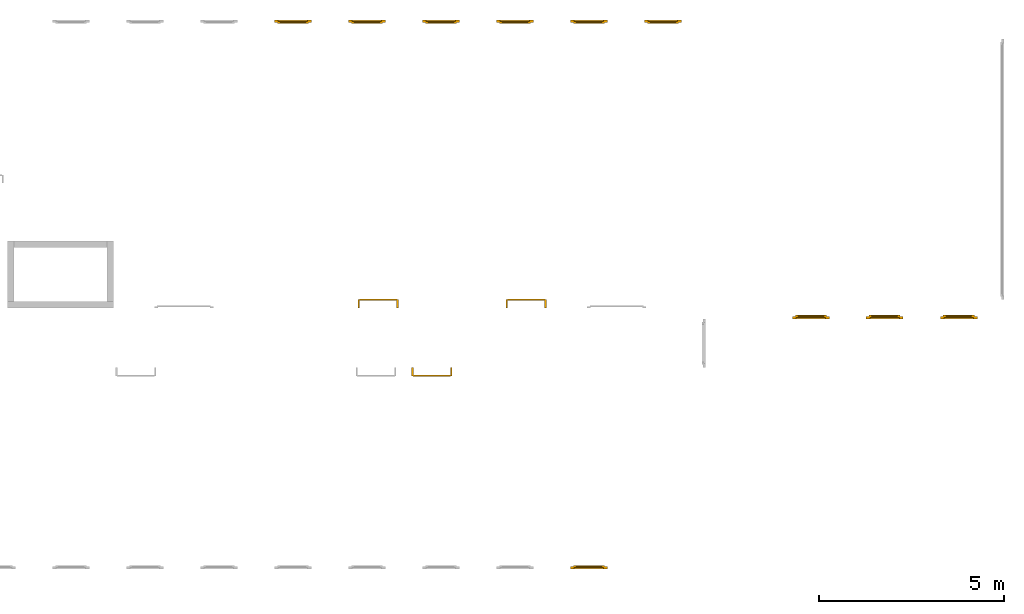
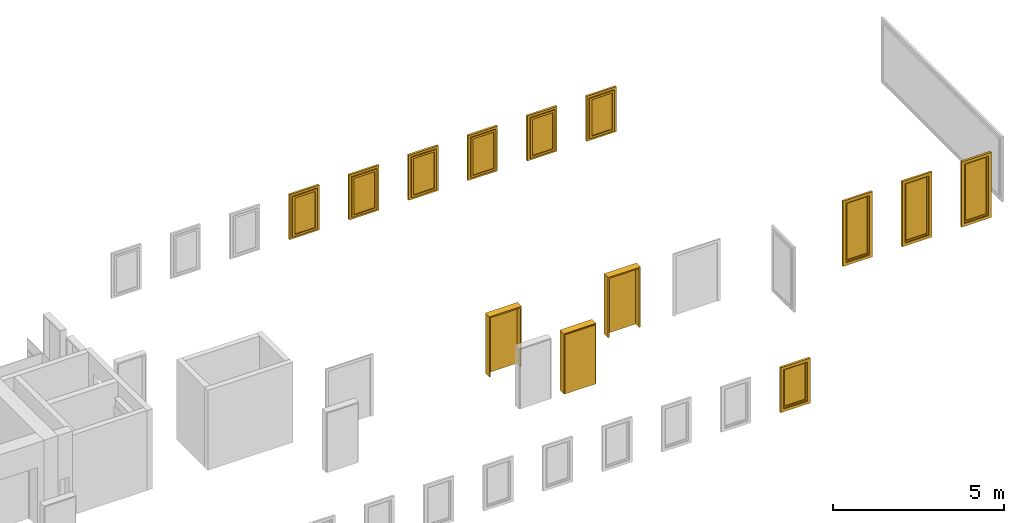
# One storey, part 4 of 5: 10 windows, 3 doors.
"""IFC4 building model written with IfcOpenShell, lengths in metres."""

from ifc_helpers import new_model, entity, si_unit, converted_unit, derived_unit, direction, frame, origin_with_axes, place, context, subcontext, project, spatial, polygons, source, transform, mapped, type_object, element, save


model = new_model("IFC4")

# Units and contexts
model_context = context("Model", 3, precision=1e-05, world=origin_with_axes(), true_north=direction((0.0, 1.0)))
body_context = subcontext(model_context, "Body", "Model", "MODEL_VIEW")
ifc_project = project(units=[si_unit("LENGTHUNIT", "METRE"), si_unit("AREAUNIT", "SQUARE_METRE"), si_unit("VOLUMEUNIT", "CUBIC_METRE"), converted_unit("PLANEANGLEUNIT", "DEGREE", entity("IfcPlaneAngleMeasure", 0.0174532925199433), si_unit("PLANEANGLEUNIT", "RADIAN"), dimensions=[0, 0, 0, 0, 0, 0, 0]), converted_unit("TIMEUNIT", "Year", entity("IfcTimeMeasure", 31557600.0), si_unit("TIMEUNIT", "SECOND"), dimensions=[0, 0, 1, 0, 0, 0, 0]), si_unit("MASSUNIT", "GRAM", prefix="KILO"), si_unit("THERMODYNAMICTEMPERATUREUNIT", "DEGREE_CELSIUS"), si_unit("LUMINOUSINTENSITYUNIT", "LUMEN"), si_unit("ENERGYUNIT", "JOULE", prefix="MEGA"), derived_unit("THERMALCONDUCTANCEUNIT", [(si_unit("POWERUNIT", "WATT"), 1), (si_unit("LENGTHUNIT", "METRE"), -1), (si_unit("THERMODYNAMICTEMPERATUREUNIT", "KELVIN"), -1)]), derived_unit("SPECIFICHEATCAPACITYUNIT", [(si_unit("ENERGYUNIT", "JOULE"), 1), (si_unit("MASSUNIT", "GRAM", prefix="KILO"), -1), (si_unit("THERMODYNAMICTEMPERATUREUNIT", "KELVIN"), -1)]), derived_unit("MASSDENSITYUNIT", [(si_unit("MASSUNIT", "GRAM", prefix="KILO"), 1), (si_unit("VOLUMEUNIT", "CUBIC_METRE"), -1)])], contexts=[model_context])

# Site, building, storey
site_placement = place(None, origin_with_axes())
site = spatial("IfcSite", under=ifc_project, at=site_placement, CompositionType="ELEMENT")
building_placement = place(None, origin_with_axes())
building = spatial("IfcBuilding", under=site, at=building_placement, CompositionType="ELEMENT")
storey_placement = place(None, frame((0.0, 0.0, 7.5), z_axis=(0.0, 0.0, 1.0), x_axis=(1.0, 0.0, 0.0)))
storey = spatial("IfcBuildingStorey", under=building, at=storey_placement, Name="2 OG", CompositionType="ELEMENT", Elevation=7.5)

# Windows
window_type = type_object("IfcWindowType", Name="1-27", PartitioningType="SINGLE_PANEL", PredefinedType="WINDOW")
shared_shape_1 = source(origin_with_axes(), body_context, "Body", "Tessellation", [
    polygons([(-0.5, -0.07, 0.0), (-0.5, 0.0, 0.0), (-0.4, 0.0, 0.1), (-0.4, -0.07, 0.1), (-0.5, -0.07, 1.6), (-0.5, 0.0, 1.6), (-0.4, 0.0, 1.5), (-0.4, -0.07, 1.5)], [[[1, 2, 3, 4]], [[5, 6, 2, 1]], [[2, 6, 7, 3]], [[4, 3, 7, 8]], [[1, 4, 8, 5]], [[8, 7, 6, 5]]], closed=True),
    polygons([(0.5, -0.07, 0.0), (0.5, 0.0, 0.0), (0.5, 0.0, 1.6), (0.5, -0.07, 1.6), (0.4, -0.07, 0.1), (0.4, 0.0, 0.1), (0.4, 0.0, 1.5), (0.4, -0.07, 1.5)], [[[1, 2, 3, 4]], [[5, 6, 2, 1]], [[2, 6, 7, 3]], [[4, 3, 7, 8]], [[1, 4, 8, 5]], [[8, 7, 6, 5]]], closed=True),
    polygons([(-0.5, -0.07, 0.0), (-0.5, 0.0, 0.0), (0.5, 0.0, 0.0), (0.5, -0.07, 0.0), (-0.4, -0.07, 0.1), (-0.4, 0.0, 0.1), (0.0, 0.0, 0.1), (0.4, 0.0, 0.1), (0.4, -0.07, 0.1), (0.0, -0.07, 0.1)], [[[1, 2, 3, 4]], [[5, 6, 2, 1]], [[2, 6, 7, 8, 3]], [[4, 3, 8, 9]], [[1, 4, 9, 10, 5]], [[10, 7, 6, 5]], [[9, 8, 7, 10]]], closed=True),
    polygons([(-0.5, -0.07, 1.6), (-0.5, 0.0, 1.6), (-0.4, 0.0, 1.5), (-0.4, -0.07, 1.5), (0.5, -0.07, 1.6), (0.5, 0.0, 1.6), (0.4, 0.0, 1.5), (0.0, 0.0, 1.5), (0.0, -0.07, 1.5), (0.4, -0.07, 1.5)], [[[1, 2, 3, 4]], [[5, 6, 2, 1]], [[2, 6, 7, 8, 3]], [[4, 3, 8, 9]], [[1, 4, 9, 10, 5]], [[10, 7, 6, 5]], [[9, 8, 7, 10]]], closed=True),
    polygons([(-0.42, 0.0, 0.08), (-0.42, 0.03, 0.08), (-0.35, 0.03, 0.15), (-0.35, 0.0, 0.15), (-0.42, 0.0, 1.52), (-0.42, 0.03, 1.52), (-0.35, 0.03, 1.45), (-0.35, 0.0, 1.45)], [[[1, 2, 3, 4]], [[5, 6, 2, 1]], [[2, 6, 7, 3]], [[4, 3, 7, 8]], [[1, 4, 8, 5]], [[8, 7, 6, 5]]], closed=True),
    polygons([(0.42, 0.0, 0.08), (0.35, 0.0, 0.15), (0.35, 0.03, 0.15), (0.42, 0.03, 0.08), (0.42, 0.0, 1.52), (0.35, 0.0, 1.45), (0.35, 0.03, 1.45), (0.42, 0.03, 1.52)], [[[1, 2, 3, 4]], [[1, 5, 6, 2]], [[2, 6, 7, 3]], [[4, 3, 7, 8]], [[5, 1, 4, 8]], [[6, 5, 8, 7]]], closed=True),
    polygons([(-0.42, 0.0, 0.08), (-0.42, 0.03, 0.08), (0.42, 0.03, 0.08), (0.42, 0.0, 0.08), (-0.35, 0.0, 0.15), (-0.35, 0.03, 0.15), (0.35, 0.03, 0.15), (0.35, 0.0, 0.15)], [[[1, 2, 3, 4]], [[5, 6, 2, 1]], [[2, 6, 7, 3]], [[4, 3, 7, 8]], [[1, 4, 8, 5]], [[8, 7, 6, 5]]], closed=True),
    polygons([(-0.42, 0.0, 1.52), (0.42, 0.0, 1.52), (0.42, 0.03, 1.52), (-0.42, 0.03, 1.52), (-0.35, 0.0, 1.45), (0.35, 0.0, 1.45), (0.35, 0.03, 1.45), (-0.35, 0.03, 1.45)], [[[1, 2, 3, 4]], [[1, 5, 6, 2]], [[2, 6, 7, 3]], [[4, 3, 7, 8]], [[5, 1, 4, 8]], [[6, 5, 8, 7]]], closed=True),
    polygons([(-0.4, -0.03, 0.1), (-0.4, 0.0, 0.1), (-0.35, 0.0, 0.15), (-0.35, -0.03, 0.15), (-0.4, -0.03, 1.5), (-0.4, 0.0, 1.5), (-0.35, 0.0, 1.45), (-0.35, -0.03, 1.45)], [[[1, 2, 3, 4]], [[5, 6, 2, 1]], [[2, 6, 7, 3]], [[4, 3, 7, 8]], [[1, 4, 8, 5]], [[8, 7, 6, 5]]], closed=True),
    polygons([(0.4, -0.03, 0.1), (0.35, -0.03, 0.15), (0.35, 0.0, 0.15), (0.4, 0.0, 0.1), (0.4, -0.03, 1.5), (0.35, -0.03, 1.45), (0.35, 0.0, 1.45), (0.4, 0.0, 1.5)], [[[1, 2, 3, 4]], [[1, 5, 6, 2]], [[2, 6, 7, 3]], [[4, 3, 7, 8]], [[5, 1, 4, 8]], [[6, 5, 8, 7]]], closed=True),
    polygons([(-0.4, -0.03, 0.1), (-0.4, 0.0, 0.1), (0.4, 0.0, 0.1), (0.4, -0.03, 0.1), (-0.35, -0.03, 0.15), (-0.35, 0.0, 0.15), (0.35, 0.0, 0.15), (0.35, -0.03, 0.15)], [[[1, 2, 3, 4]], [[5, 6, 2, 1]], [[2, 6, 7, 3]], [[4, 3, 7, 8]], [[1, 4, 8, 5]], [[8, 7, 6, 5]]], closed=True),
    polygons([(-0.4, -0.03, 1.5), (0.4, -0.03, 1.5), (0.4, 0.0, 1.5), (-0.4, 0.0, 1.5), (-0.35, -0.03, 1.45), (0.35, -0.03, 1.45), (0.35, 0.0, 1.45), (-0.35, 0.0, 1.45)], [[[1, 2, 3, 4]], [[1, 5, 6, 2]], [[2, 6, 7, 3]], [[4, 3, 7, 8]], [[5, 1, 4, 8]], [[6, 5, 8, 7]]], closed=True),
    polygons([(-0.35, -0.00500000000000001, 0.15), (-0.35, 0.00499999999999999, 0.15), (0.35, 0.00499999999999999, 0.15), (0.35, -0.00500000000000001, 0.15), (-0.35, -0.00500000000000001, 1.45), (-0.35, 0.00499999999999999, 1.45), (0.35, 0.00499999999999999, 1.45), (0.35, -0.00500000000000001, 1.45)], [[[1, 2, 3, 4]], [[5, 6, 2, 1]], [[2, 6, 7, 3]], [[4, 3, 7, 8]], [[1, 4, 8, 5]], [[8, 7, 6, 5]]], closed=True),
])
window_1_placement = place(None, frame((48.723, 0.0, 8.5), z_axis=(0.0, 0.0, 1.0), x_axis=(1.0, 0.0, 0.0)))
element("IfcWindow", 1, at=window_1_placement, inside=storey, type_object=window_type, Name="Fenster-001", OverallHeight=1.6, OverallWidth=1.0, context=body_context, shape_type="MappedRepresentation", body=[
    mapped(shared_shape_1, transform((0.5, 0.0700000000000005, 0.0))),
])
shared_shape_2 = source(origin_with_axes(), body_context, "Body", "Tessellation", [
    polygons([(-0.5, -0.07, 0.0), (-0.5, 0.0, 0.0), (-0.4, 0.0, 0.1), (-0.4, -0.07, 0.1), (-0.5, -0.07, 2.32), (-0.5, 0.0, 2.32), (-0.4, 0.0, 2.22), (-0.4, -0.07, 2.22)], [[[1, 2, 3, 4]], [[5, 6, 2, 1]], [[2, 6, 7, 3]], [[4, 3, 7, 8]], [[1, 4, 8, 5]], [[8, 7, 6, 5]]], closed=True),
    polygons([(0.5, -0.07, 0.0), (0.5, 0.0, 0.0), (0.5, 0.0, 2.32), (0.5, -0.07, 2.32), (0.4, -0.07, 0.1), (0.4, 0.0, 0.1), (0.4, 0.0, 2.22), (0.4, -0.07, 2.22)], [[[1, 2, 3, 4]], [[5, 6, 2, 1]], [[2, 6, 7, 3]], [[4, 3, 7, 8]], [[1, 4, 8, 5]], [[8, 7, 6, 5]]], closed=True),
    polygons([(-0.5, -0.07, 0.0), (-0.5, 0.0, 0.0), (0.5, 0.0, 0.0), (0.5, -0.07, 0.0), (-0.4, -0.07, 0.1), (-0.4, 0.0, 0.1), (0.0, 0.0, 0.1), (0.4, 0.0, 0.1), (0.4, -0.07, 0.1), (0.0, -0.07, 0.1)], [[[1, 2, 3, 4]], [[5, 6, 2, 1]], [[2, 6, 7, 8, 3]], [[4, 3, 8, 9]], [[1, 4, 9, 10, 5]], [[10, 7, 6, 5]], [[9, 8, 7, 10]]], closed=True),
    polygons([(-0.5, -0.07, 2.32), (-0.5, 0.0, 2.32), (-0.4, 0.0, 2.22), (-0.4, -0.07, 2.22), (0.5, -0.07, 2.32), (0.5, 0.0, 2.32), (0.4, 0.0, 2.22), (0.0, 0.0, 2.22), (0.0, -0.07, 2.22), (0.4, -0.07, 2.22)], [[[1, 2, 3, 4]], [[5, 6, 2, 1]], [[2, 6, 7, 8, 3]], [[4, 3, 8, 9]], [[1, 4, 9, 10, 5]], [[10, 7, 6, 5]], [[9, 8, 7, 10]]], closed=True),
    polygons([(-0.42, 0.0, 0.08), (-0.42, 0.03, 0.08), (-0.35, 0.03, 0.15), (-0.35, 0.0, 0.15), (-0.42, 0.0, 2.24), (-0.42, 0.03, 2.24), (-0.35, 0.03, 2.17), (-0.35, 0.0, 2.17)], [[[1, 2, 3, 4]], [[5, 6, 2, 1]], [[2, 6, 7, 3]], [[4, 3, 7, 8]], [[1, 4, 8, 5]], [[8, 7, 6, 5]]], closed=True),
    polygons([(0.42, 0.0, 0.08), (0.35, 0.0, 0.15), (0.35, 0.03, 0.15), (0.42, 0.03, 0.08), (0.42, 0.0, 2.24), (0.35, 0.0, 2.17), (0.35, 0.03, 2.17), (0.42, 0.03, 2.24)], [[[1, 2, 3, 4]], [[1, 5, 6, 2]], [[2, 6, 7, 3]], [[4, 3, 7, 8]], [[5, 1, 4, 8]], [[6, 5, 8, 7]]], closed=True),
    polygons([(-0.42, 0.0, 0.08), (-0.42, 0.03, 0.08), (0.42, 0.03, 0.08), (0.42, 0.0, 0.08), (-0.35, 0.0, 0.15), (-0.35, 0.03, 0.15), (0.35, 0.03, 0.15), (0.35, 0.0, 0.15)], [[[1, 2, 3, 4]], [[5, 6, 2, 1]], [[2, 6, 7, 3]], [[4, 3, 7, 8]], [[1, 4, 8, 5]], [[8, 7, 6, 5]]], closed=True),
    polygons([(-0.42, 0.0, 2.24), (0.42, 0.0, 2.24), (0.42, 0.03, 2.24), (-0.42, 0.03, 2.24), (-0.35, 0.0, 2.17), (0.35, 0.0, 2.17), (0.35, 0.03, 2.17), (-0.35, 0.03, 2.17)], [[[1, 2, 3, 4]], [[1, 5, 6, 2]], [[2, 6, 7, 3]], [[4, 3, 7, 8]], [[5, 1, 4, 8]], [[6, 5, 8, 7]]], closed=True),
    polygons([(-0.4, -0.03, 0.1), (-0.4, 0.0, 0.1), (-0.35, 0.0, 0.15), (-0.35, -0.03, 0.15), (-0.4, -0.03, 2.22), (-0.4, 0.0, 2.22), (-0.35, 0.0, 2.17), (-0.35, -0.03, 2.17)], [[[1, 2, 3, 4]], [[5, 6, 2, 1]], [[2, 6, 7, 3]], [[4, 3, 7, 8]], [[1, 4, 8, 5]], [[8, 7, 6, 5]]], closed=True),
    polygons([(0.4, -0.03, 0.1), (0.35, -0.03, 0.15), (0.35, 0.0, 0.15), (0.4, 0.0, 0.1), (0.4, -0.03, 2.22), (0.35, -0.03, 2.17), (0.35, 0.0, 2.17), (0.4, 0.0, 2.22)], [[[1, 2, 3, 4]], [[1, 5, 6, 2]], [[2, 6, 7, 3]], [[4, 3, 7, 8]], [[5, 1, 4, 8]], [[6, 5, 8, 7]]], closed=True),
    polygons([(-0.4, -0.03, 0.1), (-0.4, 0.0, 0.1), (0.4, 0.0, 0.1), (0.4, -0.03, 0.1), (-0.35, -0.03, 0.15), (-0.35, 0.0, 0.15), (0.35, 0.0, 0.15), (0.35, -0.03, 0.15)], [[[1, 2, 3, 4]], [[5, 6, 2, 1]], [[2, 6, 7, 3]], [[4, 3, 7, 8]], [[1, 4, 8, 5]], [[8, 7, 6, 5]]], closed=True),
    polygons([(-0.4, -0.03, 2.22), (0.4, -0.03, 2.22), (0.4, 0.0, 2.22), (-0.4, 0.0, 2.22), (-0.35, -0.03, 2.17), (0.35, -0.03, 2.17), (0.35, 0.0, 2.17), (-0.35, 0.0, 2.17)], [[[1, 2, 3, 4]], [[1, 5, 6, 2]], [[2, 6, 7, 3]], [[4, 3, 7, 8]], [[5, 1, 4, 8]], [[6, 5, 8, 7]]], closed=True),
    polygons([(-0.35, -0.00500000000000001, 0.15), (-0.35, 0.00499999999999999, 0.15), (0.35, 0.00499999999999999, 0.15), (0.35, -0.00500000000000001, 0.15), (-0.35, -0.00500000000000001, 2.17), (-0.35, 0.00499999999999999, 2.17), (0.35, 0.00499999999999999, 2.17), (0.35, -0.00500000000000001, 2.17)], [[[1, 2, 3, 4]], [[5, 6, 2, 1]], [[2, 6, 7, 3]], [[4, 3, 7, 8]], [[1, 4, 8, 5]], [[8, 7, 6, 5]]], closed=True),
])
window_2_placement = place(None, frame((54.7256338620337, 6.76749994546756, 7.5), z_axis=(0.0, 0.0, 1.0), x_axis=(1.0, 0.0, 0.0)))
element("IfcWindow", 2, at=window_2_placement, inside=storey, type_object=window_type, Name="Fenster-001", OverallHeight=2.32, OverallWidth=1.0, context=body_context, shape_type="MappedRepresentation", body=[
    mapped(shared_shape_2, transform((0.5, 0.0700000000000003, 0.0))),
])
for number, where, z_axis, x_axis, name in (
    (3, (58.723, 6.76749994546756, 7.5), (0.0, 0.0, 1.0), (1.0, 0.0, 0.0), "Fenster-001"),
    (4, (56.7209324704699, 6.76749994546756, 7.5), (0.0, 0.0, 1.0), (1.0, 0.0, 0.0), "Fenster-001"),
):
    element("IfcWindow", number, at=place(None, frame(where, z_axis=z_axis, x_axis=x_axis)), inside=storey, type_object=window_type, Name=name, OverallHeight=2.32, OverallWidth=1.0, context=body_context, shape_type="MappedRepresentation", body=[
        mapped(shared_shape_2, transform((0.5, 0.0699999999999994, 0.0))),
    ])
shared_shape_3 = source(origin_with_axes(), body_context, "Body", "Tessellation", [
    polygons([(0.5, -0.07, 0.0), (0.4, -0.07, 0.1), (0.4, 0.0, 0.1), (0.5, 0.0, 0.0), (0.5, -0.07, 1.6), (0.4, -0.07, 1.5), (0.4, 0.0, 1.5), (0.5, 0.0, 1.6)], [[[1, 2, 3, 4]], [[1, 5, 6, 2]], [[2, 6, 7, 3]], [[4, 3, 7, 8]], [[5, 1, 4, 8]], [[6, 5, 8, 7]]], closed=True),
    polygons([(-0.5, -0.07, 0.0), (-0.5, -0.07, 1.6), (-0.5, 0.0, 1.6), (-0.5, 0.0, 0.0), (-0.4, -0.07, 0.1), (-0.4, -0.07, 1.5), (-0.4, 0.0, 1.5), (-0.4, 0.0, 0.1)], [[[1, 2, 3, 4]], [[1, 5, 6, 2]], [[2, 6, 7, 3]], [[4, 3, 7, 8]], [[5, 1, 4, 8]], [[6, 5, 8, 7]]], closed=True),
    polygons([(0.5, -0.07, 0.0), (-0.5, -0.07, 0.0), (-0.5, 0.0, 0.0), (0.5, 0.0, 0.0), (0.4, -0.07, 0.1), (0.0, -0.07, 0.1), (-0.4, -0.07, 0.1), (-0.4, 0.0, 0.1), (0.0, 0.0, 0.1), (0.4, 0.0, 0.1)], [[[1, 2, 3, 4]], [[1, 5, 6, 7, 2]], [[2, 7, 8, 3]], [[4, 3, 8, 9, 10]], [[5, 1, 4, 10]], [[6, 5, 10, 9]], [[7, 6, 9, 8]]], closed=True),
    polygons([(0.5, -0.07, 1.6), (0.4, -0.07, 1.5), (0.4, 0.0, 1.5), (0.5, 0.0, 1.6), (-0.5, -0.07, 1.6), (-0.4, -0.07, 1.5), (0.0, -0.07, 1.5), (0.0, 0.0, 1.5), (-0.4, 0.0, 1.5), (-0.5, 0.0, 1.6)], [[[1, 2, 3, 4]], [[1, 5, 6, 7, 2]], [[2, 7, 8, 3]], [[4, 3, 8, 9, 10]], [[5, 1, 4, 10]], [[6, 5, 10, 9]], [[7, 6, 9, 8]]], closed=True),
    polygons([(0.42, 0.0, 0.08), (0.35, 0.0, 0.15), (0.35, 0.03, 0.15), (0.42, 0.03, 0.08), (0.42, 0.0, 1.52), (0.35, 0.0, 1.45), (0.35, 0.03, 1.45), (0.42, 0.03, 1.52)], [[[1, 2, 3, 4]], [[1, 5, 6, 2]], [[2, 6, 7, 3]], [[4, 3, 7, 8]], [[5, 1, 4, 8]], [[6, 5, 8, 7]]], closed=True),
    polygons([(-0.42, 0.0, 0.08), (-0.42, 0.03, 0.08), (-0.35, 0.03, 0.15), (-0.35, 0.0, 0.15), (-0.42, 0.0, 1.52), (-0.42, 0.03, 1.52), (-0.35, 0.03, 1.45), (-0.35, 0.0, 1.45)], [[[1, 2, 3, 4]], [[5, 6, 2, 1]], [[2, 6, 7, 3]], [[4, 3, 7, 8]], [[1, 4, 8, 5]], [[8, 7, 6, 5]]], closed=True),
    polygons([(0.42, 0.0, 0.08), (-0.42, 0.0, 0.08), (-0.42, 0.03, 0.08), (0.42, 0.03, 0.08), (0.35, 0.0, 0.15), (-0.35, 0.0, 0.15), (-0.35, 0.03, 0.15), (0.35, 0.03, 0.15)], [[[1, 2, 3, 4]], [[1, 5, 6, 2]], [[2, 6, 7, 3]], [[4, 3, 7, 8]], [[5, 1, 4, 8]], [[6, 5, 8, 7]]], closed=True),
    polygons([(0.42, 0.0, 1.52), (0.42, 0.03, 1.52), (-0.42, 0.03, 1.52), (-0.42, 0.0, 1.52), (0.35, 0.0, 1.45), (0.35, 0.03, 1.45), (-0.35, 0.03, 1.45), (-0.35, 0.0, 1.45)], [[[1, 2, 3, 4]], [[5, 6, 2, 1]], [[2, 6, 7, 3]], [[4, 3, 7, 8]], [[1, 4, 8, 5]], [[8, 7, 6, 5]]], closed=True),
    polygons([(0.4, -0.03, 0.1), (0.35, -0.03, 0.15), (0.35, 0.0, 0.15), (0.4, 0.0, 0.1), (0.4, -0.03, 1.5), (0.35, -0.03, 1.45), (0.35, 0.0, 1.45), (0.4, 0.0, 1.5)], [[[1, 2, 3, 4]], [[1, 5, 6, 2]], [[2, 6, 7, 3]], [[4, 3, 7, 8]], [[5, 1, 4, 8]], [[6, 5, 8, 7]]], closed=True),
    polygons([(-0.4, -0.03, 0.1), (-0.4, 0.0, 0.1), (-0.35, 0.0, 0.15), (-0.35, -0.03, 0.15), (-0.4, -0.03, 1.5), (-0.4, 0.0, 1.5), (-0.35, 0.0, 1.45), (-0.35, -0.03, 1.45)], [[[1, 2, 3, 4]], [[5, 6, 2, 1]], [[2, 6, 7, 3]], [[4, 3, 7, 8]], [[1, 4, 8, 5]], [[8, 7, 6, 5]]], closed=True),
    polygons([(0.4, -0.03, 0.1), (-0.4, -0.03, 0.1), (-0.4, 0.0, 0.1), (0.4, 0.0, 0.1), (0.35, -0.03, 0.15), (-0.35, -0.03, 0.15), (-0.35, 0.0, 0.15), (0.35, 0.0, 0.15)], [[[1, 2, 3, 4]], [[1, 5, 6, 2]], [[2, 6, 7, 3]], [[4, 3, 7, 8]], [[5, 1, 4, 8]], [[6, 5, 8, 7]]], closed=True),
    polygons([(0.4, -0.03, 1.5), (0.4, 0.0, 1.5), (-0.4, 0.0, 1.5), (-0.4, -0.03, 1.5), (0.35, -0.03, 1.45), (0.35, 0.0, 1.45), (-0.35, 0.0, 1.45), (-0.35, -0.03, 1.45)], [[[1, 2, 3, 4]], [[5, 6, 2, 1]], [[2, 6, 7, 3]], [[4, 3, 7, 8]], [[1, 4, 8, 5]], [[8, 7, 6, 5]]], closed=True),
    polygons([(0.35, -0.00500000000000001, 0.15), (-0.35, -0.00500000000000001, 0.15), (-0.35, 0.00499999999999999, 0.15), (0.35, 0.00499999999999999, 0.15), (0.35, -0.00500000000000001, 1.45), (-0.35, -0.00500000000000001, 1.45), (-0.35, 0.00499999999999999, 1.45), (0.35, 0.00499999999999999, 1.45)], [[[1, 2, 3, 4]], [[1, 5, 6, 2]], [[2, 6, 7, 3]], [[4, 3, 7, 8]], [[5, 1, 4, 8]], [[6, 5, 8, 7]]], closed=True),
])
for number, where, z_axis, x_axis, name in (
    (5, (47.723, 14.8459998909351, 8.5), (0.0, 0.0, 1.0), (-1.0, 0.0, 0.0), "Fenster-001"),
    (6, (41.723, 14.8459998909351, 8.5), (0.0, 0.0, 1.0), (-1.0, 0.0, 0.0), "Fenster-001"),
    (7, (51.723, 14.8459998909351, 8.5), (0.0, 0.0, 1.0), (-1.0, 0.0, 0.0), "Fenster-001"),
    (8, (45.723, 14.8459998909351, 8.5), (0.0, 0.0, 1.0), (-1.0, 0.0, 0.0), "Fenster-001"),
    (9, (49.723, 14.8459998909351, 8.5), (0.0, 0.0, 1.0), (-1.0, 0.0, 0.0), "Fenster-001"),
    (10, (43.723, 14.8459998909351, 8.5), (0.0, 0.0, 1.0), (-1.0, 0.0, 0.0), "Fenster-001"),
):
    element("IfcWindow", number, at=place(None, frame(where, z_axis=z_axis, x_axis=x_axis)), inside=storey, type_object=window_type, Name=name, OverallHeight=1.6, OverallWidth=1.0, context=body_context, shape_type="MappedRepresentation", body=[
        mapped(shared_shape_3, transform((0.5, 0.0699999999999985, 0.0))),
    ])

# Doors
door_type = type_object("IfcDoorType", Name="27", OperationType="SINGLE_SWING_RIGHT", PredefinedType="DOOR")
shared_shape_4 = source(origin_with_axes(), body_context, "Body", "Tessellation", [
    polygons([(0.545, -0.2325, 0.0), (0.545, -0.025, 0.0), (0.545, -0.025, 2.145), (0.545, -0.2325, 2.145), (0.5, -0.2325, 0.0), (0.5, -0.025, 0.0), (0.5, -0.025, 2.1), (0.0551, -0.025, 2.1), (0.0001, -0.025, 2.1), (-0.5, -0.025, 2.1), (-0.5, -0.025, 0.0), (-0.545, -0.025, 0.0), (-0.545, -0.025, 2.145), (-0.545, -0.2325, 2.145), (-0.545, -0.2325, 0.0), (-0.5, -0.2325, 0.0), (-0.5, -0.2325, 2.1), (0.0001, -0.2325, 2.1), (0.0551, -0.2325, 2.1), (0.5, -0.2325, 2.1)], [[[1, 2, 3, 4]], [[5, 6, 2, 1]], [[2, 6, 7, 8, 9, 10, 11, 12, 13, 3]], [[4, 3, 13, 14]], [[1, 4, 14, 15, 16, 17, 18, 19, 20, 5]], [[20, 7, 6, 5]], [[19, 8, 7, 20]], [[18, 9, 8, 19]], [[17, 10, 9, 18]], [[16, 11, 10, 17]], [[15, 12, 11, 16]], [[14, 13, 12, 15]]], closed=True),
    polygons([(0.545, -0.025, 0.0), (0.545, 0.0, 0.0), (0.545, 0.0, 2.145), (0.545, -0.025, 2.145), (0.51, -0.025, 0.0), (0.51, 0.0, 0.0), (0.51, 0.0, 2.11), (0.0451, 0.0, 2.11), (0.0101, 0.0, 2.11), (-0.51, 0.0, 2.11), (-0.51, 0.0, 0.0), (-0.545, 0.0, 0.0), (-0.545, 0.0, 2.145), (-0.545, -0.025, 2.145), (-0.545, -0.025, 0.0), (-0.51, -0.025, 0.0), (-0.51, -0.025, 2.11), (0.0101, -0.025, 2.11), (0.0451, -0.025, 2.11), (0.51, -0.025, 2.11)], [[[1, 2, 3, 4]], [[5, 6, 2, 1]], [[2, 6, 7, 8, 9, 10, 11, 12, 13, 3]], [[4, 3, 13, 14]], [[1, 4, 14, 15, 16, 17, 18, 19, 20, 5]], [[20, 7, 6, 5]], [[19, 8, 7, 20]], [[18, 9, 8, 19]], [[17, 10, 9, 18]], [[16, 11, 10, 17]], [[15, 12, 11, 16]], [[14, 13, 12, 15]]], closed=True),
    polygons([(0.51, 0.015, 0.0), (-0.51, 0.015, 0.0), (-0.51, 0.015, 2.11), (0.51, 0.015, 2.11), (0.51, -0.025, 0.0), (-0.51, -0.025, 0.0), (-0.51, -0.025, 2.11), (0.51, -0.025, 2.11)], [[[1, 2, 3, 4]], [[2, 1, 5, 6]], [[3, 2, 6, 7]], [[4, 3, 7, 8]], [[1, 4, 8, 5]], [[6, 5, 8, 7]]], closed=True),
])
door_placement = place(None, frame((45.477, 5.45499994546755, 7.5), z_axis=(0.0, 0.0, 1.0), x_axis=(-1.0, 0.0, 0.0)))
element("IfcDoor", 11, at=door_placement, inside=storey, type_object=door_type, OverallHeight=2.145, OverallWidth=1.09, context=body_context, shape_type="MappedRepresentation", body=[
    mapped(shared_shape_4, transform((0.5, 0.2325, 0.0))),
])
for number, where, z_axis, x_axis in (
    (12, (47.028, 7.05499994546756, 7.5), (0.0, 0.0, 1.0), (1.0, 0.0, 0.0)),
    (13, (43.028, 7.05499994546756, 7.5), (0.0, 0.0, 1.0), (1.0, 0.0, 0.0)),
):
    element("IfcDoor", number, at=place(None, frame(where, z_axis=z_axis, x_axis=x_axis)), inside=storey, type_object=door_type, OverallHeight=2.145, OverallWidth=1.09, context=body_context, shape_type="MappedRepresentation", body=[
        mapped(shared_shape_4, transform((0.5, 0.232500000000001, 0.0))),
    ])

save(model, "model.ifc")
